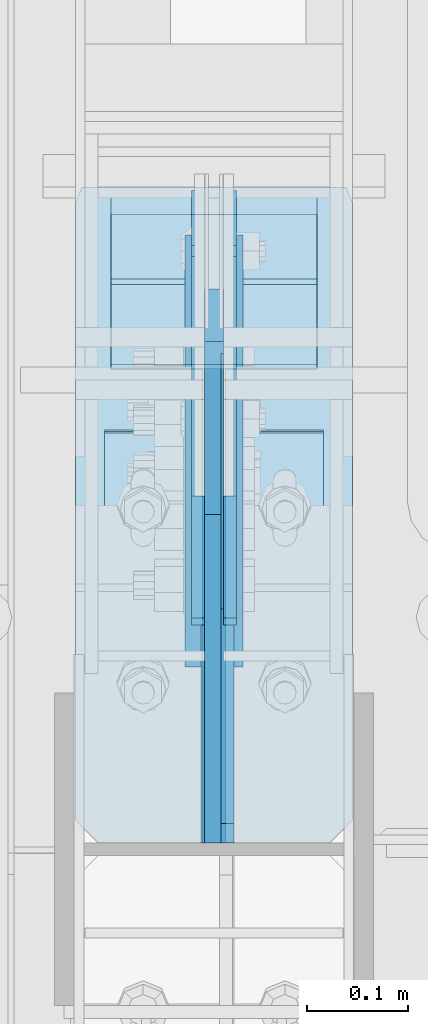
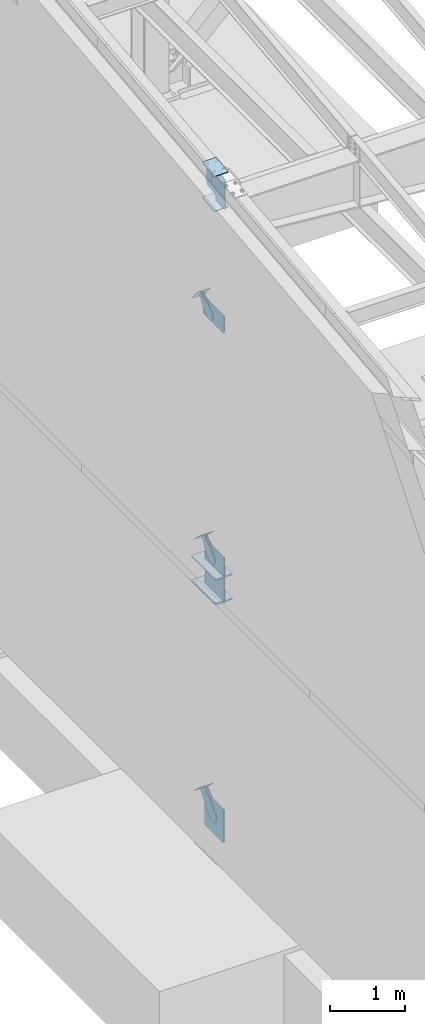
# One storey, part 991 of 1179: 17 plates, 10 elements without a shape of their own.
"""IFC2X3 building model written with IfcOpenShell, lengths in millimetres."""

from ifc_helpers import new_model, si_unit, frame, origin_with_axes, place, context, subcontext, project, spatial, faceted_brep, material, type_object, element, aggregate, save


model = new_model("IFC2X3")

# Units and contexts
model_context = context("Model", 3, precision=1e-05, world=origin_with_axes())
body_context = subcontext(model_context, "Body", "Model", "MODEL_VIEW")
ifc_project = project(units=[si_unit("LENGTHUNIT", "METRE", prefix="MILLI"), si_unit("AREAUNIT", "SQUARE_METRE"), si_unit("VOLUMEUNIT", "CUBIC_METRE"), si_unit("MASSUNIT", "GRAM", prefix="KILO"), si_unit("TIMEUNIT", "SECOND"), si_unit("PLANEANGLEUNIT", "RADIAN"), si_unit("SOLIDANGLEUNIT", "STERADIAN"), si_unit("THERMODYNAMICTEMPERATUREUNIT", "DEGREE_CELSIUS"), si_unit("LUMINOUSINTENSITYUNIT", "LUMEN")], contexts=[model_context])

# Site, building, storey
site_placement = place(None, origin_with_axes())
site = spatial("IfcSite", under=ifc_project, at=site_placement, CompositionType="ELEMENT")
building_placement = place(site_placement, origin_with_axes())
building = spatial("IfcBuilding", under=site, at=building_placement, Name="Undefined", CompositionType="ELEMENT")
storey_placement = place(building_placement, origin_with_axes())
storey = spatial("IfcBuildingStorey", under=building, at=storey_placement, Name="Undefined", CompositionType="ELEMENT", Elevation=0.0)

# Assembly, plates
assembly_1_placement = place(storey_placement, origin_with_axes())
assembly_1 = element("IfcElementAssembly", 1, at=assembly_1_placement, inside=storey, Name="COLUMN", AssemblyPlace="NOTDEFINED", PredefinedType="RIGID_FRAME")
ifc_material_1 = material(Name="STEEL/A572-GR.50")
plate_type_1 = type_object("IfcPlateType", PredefinedType="NOTDEFINED")
plate_1_placement = place(assembly_1_placement, frame((295.275012207031, 12133.5984303375, 3694.1125), z_axis=(0.0, -1.0, 0.0), x_axis=(1.0, 0.0, 0.0)))
plate_1 = element("IfcPlate", 2, at=plate_1_placement, type_object=plate_type_1, material=ifc_material_1, Name="PLATE", context=body_context, shape_type="Brep", body=[
    faceted_brep([(125.412487792968, -11.1125000000002, 646.448430322878), (125.412487792968, -11.1125000000002, 153.987500190735), (125.412487792968, 11.1125000000002, 153.987500190735), (125.412487792968, 11.1125000000002, 646.448430322878), (126.258376502454, -11.1125000000002, 149.734930475586), (126.258376502454, 11.1125000000002, 149.734930475586), (128.667263742896, -11.1125000000002, 146.12977594993), (128.667263742896, 11.1125000000002, 146.12977594993), (132.272418268556, -11.1125000000002, 143.720888709488), (132.272418268556, 11.1125000000002, 143.720888709488), (136.524987602239, -11.1125000000002, 142.875), (136.524987602239, 11.1125000000002, 142.875), (140.777557317386, -11.1125000000002, 143.720888709488), (140.777557317386, 11.1125000000002, 143.720888709488), (144.382711843045, -11.1125000000002, 146.12977594993), (144.382711843045, 11.1125000000002, 146.12977594993), (146.791599083488, -11.1125000000002, 149.734930475586), (146.791599083488, 11.1125000000002, 149.734930475586), (147.637487792974, -11.1125000000002, 153.987500190735), (147.637487792974, 11.1125000000002, 153.987500190735), (147.637487792974, -11.1125000000002, 646.448430322878), (147.637487792974, 11.1125000000002, 646.448430322878), (0.0, -11.1125000000002, 624.223429941409), (22.2250003814697, -11.1125000000002, 646.448430322878), (22.2250003814697, 11.1125000000002, 646.448430322878), (0.0, 11.1125000000002, 624.223429941409), (0.0, -11.1125000000002, 15.875), (0.0, 11.1125000000002, 15.875), (6.34999990463257, -11.1125000000002, 0.0), (6.34999990463257, 11.1125000000002, 0.0), (266.699987888336, -11.1125000000002, 0.0), (266.699987888336, 11.1125000000002, 0.0), (273.049987792969, -11.1125000000002, 15.875), (273.049987792969, 11.1125000000002, 15.875), (273.049987792969, -11.1125000000002, 624.223429941409), (273.049987792969, 11.1125000000002, 624.223429941409), (250.824987411499, -11.1125000000002, 646.448430322878), (250.824987411499, 11.1125000000002, 646.448430322878)], [[[0, 1, 2, 3]], [[4, 5, 2, 1]], [[6, 7, 5, 4]], [[8, 9, 7, 6]], [[10, 11, 9, 8]], [[12, 13, 11, 10]], [[14, 15, 13, 12]], [[16, 17, 15, 14]], [[18, 19, 17, 16]], [[20, 21, 19, 18]], [[22, 23, 24, 25]], [[26, 22, 25, 27]], [[28, 26, 27, 29]], [[30, 28, 29, 31]], [[32, 30, 31, 33]], [[34, 32, 33, 35]], [[36, 34, 35, 37]], [[16, 14, 12, 10, 8, 6, 4, 1, 0, 23, 22, 26, 28, 30, 32, 34, 36, 20, 18]], [[24, 23, 0, 3]], [[37, 35, 33, 31, 29, 27, 25, 24, 3, 2, 5, 7, 9, 11, 13, 15, 17, 19, 21]], [[36, 37, 21, 20]]]),
])
plate_2_placement = place(assembly_1_placement, frame((295.275012207031, 12133.5984303375, 4090.9875), z_axis=(0.0, -1.0, 0.0), x_axis=(1.0, 0.0, 0.0)))
plate_2 = element("IfcPlate", 3, at=plate_2_placement, type_object=plate_type_1, material=ifc_material_1, Name="PLATE", context=body_context, shape_type="Brep", body=[
    faceted_brep([(125.412487792968, -11.1125000000002, 646.448430322878), (125.412487792968, -11.1125000000002, 153.987500190735), (125.412487792968, 11.1125000000002, 153.987500190735), (125.412487792968, 11.1125000000002, 646.448430322878), (126.258376502454, -11.1125000000002, 149.734930475586), (126.258376502454, 11.1125000000002, 149.734930475586), (128.667263742896, -11.1125000000002, 146.12977594993), (128.667263742896, 11.1125000000002, 146.12977594993), (132.272418268556, -11.1125000000002, 143.720888709488), (132.272418268556, 11.1125000000002, 143.720888709488), (136.524987602239, -11.1125000000002, 142.875), (136.524987602239, 11.1125000000002, 142.875), (140.777557317386, -11.1125000000002, 143.720888709488), (140.777557317386, 11.1125000000002, 143.720888709488), (144.382711843045, -11.1125000000002, 146.12977594993), (144.382711843045, 11.1125000000002, 146.12977594993), (146.791599083488, -11.1125000000002, 149.734930475586), (146.791599083488, 11.1125000000002, 149.734930475586), (147.637487792974, -11.1125000000002, 153.987500190735), (147.637487792974, 11.1125000000002, 153.987500190735), (147.637487792974, -11.1125000000002, 646.448430322878), (147.637487792974, 11.1125000000002, 646.448430322878), (0.0, -11.1125000000002, 624.223429941409), (22.2250003814697, -11.1125000000002, 646.448430322878), (22.2250003814697, 11.1125000000002, 646.448430322878), (0.0, 11.1125000000002, 624.223429941409), (0.0, -11.1125000000002, 15.875), (0.0, 11.1125000000002, 15.875), (6.34999990463257, -11.1125000000002, 0.0), (6.34999990463257, 11.1125000000002, 0.0), (266.699987888336, -11.1125000000002, 0.0), (266.699987888336, 11.1125000000002, 0.0), (273.049987792969, -11.1125000000002, 15.875), (273.049987792969, 11.1125000000002, 15.875), (273.049987792969, -11.1125000000002, 624.223429941409), (273.049987792969, 11.1125000000002, 624.223429941409), (250.824987411499, -11.1125000000002, 646.448430322878), (250.824987411499, 11.1125000000002, 646.448430322878)], [[[0, 1, 2, 3]], [[4, 5, 2, 1]], [[6, 7, 5, 4]], [[8, 9, 7, 6]], [[10, 11, 9, 8]], [[12, 13, 11, 10]], [[14, 15, 13, 12]], [[16, 17, 15, 14]], [[18, 19, 17, 16]], [[20, 21, 19, 18]], [[22, 23, 24, 25]], [[26, 22, 25, 27]], [[28, 26, 27, 29]], [[30, 28, 29, 31]], [[32, 30, 31, 33]], [[34, 32, 33, 35]], [[36, 34, 35, 37]], [[16, 14, 12, 10, 8, 6, 4, 1, 0, 23, 22, 26, 28, 30, 32, 34, 36, 20, 18]], [[24, 23, 0, 3]], [[37, 35, 33, 31, 29, 27, 25, 24, 3, 2, 5, 7, 9, 11, 13, 15, 17, 19, 21]], [[36, 37, 21, 20]]]),
])

# Assembly, plate
assembly_2_placement = place(storey_placement, origin_with_axes())
assembly_2 = element("IfcElementAssembly", 4, at=assembly_2_placement, inside=storey, AssemblyPlace="NOTDEFINED", PredefinedType="RIGID_FRAME")
ifc_material_2 = material(Name="STEEL/A36")
plate_type_2 = type_object("IfcPlateType", PredefinedType="NOTDEFINED")
plate_3_placement = place(assembly_2_placement, frame((415.925000000002, 12073.4870321748, 8239.67476675301), z_axis=(0.0, -0.591856615182528, 0.806043266248581), x_axis=(0.0, 0.806043266248581, 0.591856615182528)))
plate_3 = element("IfcPlate", 5, at=plate_3_placement, type_object=plate_type_2, material=ifc_material_2, context=body_context, shape_type="Brep", body=[
    faceted_brep([(0.0, -6.34999999999854, 0.0), (-101.600000000211, -6.34999999999854, -44.6881937825565), (-101.600000000211, 6.34999999999854, -44.6881937825565), (0.0, 6.34999999999854, 0.0), (-246.684985848258, -6.34999999999854, -44.6881937827675), (-246.684985848258, 6.34999999999854, -44.6881937827675), (-281.313054102191, -6.34999999999854, -37.800242748639), (-281.313054102191, 6.34999999999854, -37.800242748639), (-310.669312868691, -6.34999999999854, -18.1850177516608), (-310.669312868691, 6.34999999999854, -18.1850177516608), (-330.284537865713, -6.34999999999854, 11.1712410148393), (-330.284537865713, 6.34999999999854, 11.1712410148393), (-337.172488899912, -6.34999999999854, 45.7993031647638), (-337.172488899912, 6.34999999999854, 45.7993031647638), (-330.284537865768, -6.34999999999854, 80.4273714187839), (-330.284537865768, 6.34999999999854, 80.4273714187839), (-310.669312868773, -6.34999999999854, 109.783630185371), (-310.669312868773, 6.34999999999854, 109.783630185371), (-281.313054102271, -6.34999999999854, 129.398855182466), (-281.313054102271, 6.34999999999854, 129.398855182466), (-246.684988899762, -6.34999999999854, 136.286806216707), (-246.684988899762, 6.34999999999854, 136.286806216707), (-101.600000000377, -6.34999999999854, 136.286806216911), (-101.600000000377, 6.34999999999854, 136.286806216911), (-8.18545231595635e-11, -6.34999999999854, 91.5986124346418), (-8.18545231595635e-11, 6.34999999999854, 91.5986124346418), (69.8500000000859, -6.35000000000002, 91.598612434588), (69.8500000000859, 6.35000000000002, 91.598612434588), (69.849999425729, -6.34999999999854, 0.0), (69.849999425729, 6.34999999999854, 0.0)], [[[0, 1, 2, 3]], [[1, 4, 5, 2]], [[4, 6, 7, 5]], [[6, 8, 9, 7]], [[8, 10, 11, 9]], [[10, 12, 13, 11]], [[12, 14, 15, 13]], [[14, 16, 17, 15]], [[16, 18, 19, 17]], [[18, 20, 21, 19]], [[20, 22, 23, 21]], [[22, 24, 25, 23]], [[24, 26, 27, 25]], [[26, 28, 29, 27]], [[28, 0, 3, 29]], [[5, 7, 9, 11, 13, 15, 17, 19, 21, 23, 25, 27, 29, 3, 2]], [[28, 26, 24, 22, 20, 18, 16, 14, 12, 10, 8, 6, 4, 1, 0]]]),
])
aggregate(assembly_2, [plate_3])

assembly_3_placement = place(storey_placement, origin_with_axes())
assembly_3 = element("IfcElementAssembly", 6, at=assembly_3_placement, inside=storey, AssemblyPlace="NOTDEFINED", PredefinedType="RIGID_FRAME")
plate_4_placement = place(assembly_3_placement, frame((447.675000000002, 12073.4870321748, 8239.67476675301), z_axis=(0.0, -0.591856615182528, 0.806043266248581), x_axis=(0.0, 0.806043266248581, 0.591856615182528)))
plate_4 = element("IfcPlate", 7, at=plate_4_placement, type_object=plate_type_2, material=ifc_material_2, context=body_context, shape_type="Brep", body=[
    faceted_brep([(0.0, -6.34999999999854, 0.0), (-101.600000000211, -6.34999999999854, -44.6881937825565), (-101.600000000211, 6.34999999999854, -44.6881937825565), (0.0, 6.34999999999854, 0.0), (-246.684985848258, -6.34999999999854, -44.6881937827675), (-246.684985848258, 6.34999999999854, -44.6881937827675), (-281.313054102191, -6.34999999999854, -37.800242748639), (-281.313054102191, 6.34999999999854, -37.800242748639), (-310.669312868691, -6.34999999999854, -18.1850177516608), (-310.669312868691, 6.34999999999854, -18.1850177516608), (-330.284537865713, -6.34999999999854, 11.1712410148393), (-330.284537865713, 6.34999999999854, 11.1712410148393), (-337.172488899912, -6.34999999999854, 45.7993031647638), (-337.172488899912, 6.34999999999854, 45.7993031647638), (-330.284537865768, -6.34999999999854, 80.4273714187839), (-330.284537865768, 6.34999999999854, 80.4273714187839), (-310.669312868773, -6.34999999999854, 109.783630185371), (-310.669312868773, 6.34999999999854, 109.783630185371), (-281.313054102271, -6.34999999999854, 129.398855182466), (-281.313054102271, 6.34999999999854, 129.398855182466), (-246.684988899762, -6.34999999999854, 136.286806216707), (-246.684988899762, 6.34999999999854, 136.286806216707), (-101.600000000377, -6.34999999999854, 136.286806216911), (-101.600000000377, 6.34999999999854, 136.286806216911), (-8.18545231595635e-11, -6.34999999999854, 91.5986124346418), (-8.18545231595635e-11, 6.34999999999854, 91.5986124346418), (69.8500000000859, -6.35000000000002, 91.598612434588), (69.8500000000859, 6.35000000000002, 91.598612434588), (69.849999425729, -6.34999999999854, 0.0), (69.849999425729, 6.34999999999854, 0.0)], [[[0, 1, 2, 3]], [[1, 4, 5, 2]], [[4, 6, 7, 5]], [[6, 8, 9, 7]], [[8, 10, 11, 9]], [[10, 12, 13, 11]], [[12, 14, 15, 13]], [[14, 16, 17, 15]], [[16, 18, 19, 17]], [[18, 20, 21, 19]], [[20, 22, 23, 21]], [[22, 24, 25, 23]], [[24, 26, 27, 25]], [[26, 28, 29, 27]], [[28, 0, 3, 29]], [[5, 7, 9, 11, 13, 15, 17, 19, 21, 23, 25, 27, 29, 3, 2]], [[28, 26, 24, 22, 20, 18, 16, 14, 12, 10, 8, 6, 4, 1, 0]]]),
])
aggregate(assembly_3, [plate_4])

assembly_4_placement = place(storey_placement, origin_with_axes())
assembly_4 = element("IfcElementAssembly", 8, at=assembly_4_placement, inside=storey, Name="Plate", AssemblyPlace="NOTDEFINED", PredefinedType="RIGID_FRAME")
plate_type_3 = type_object("IfcPlateType", PredefinedType="NOTDEFINED")
plate_5_placement = place(assembly_4_placement, frame((533.400000000002, 12160.2559766978, 8234.1590330937), z_axis=(0.0, -0.591856615182528, 0.806043266248581), x_axis=(-1.0, 0.0, 0.0)))
plate_5 = element("IfcPlate", 9, at=plate_5_placement, type_object=plate_type_3, material=ifc_material_2, Name="Plate", context=body_context, shape_type="Brep", body=[
    faceted_brep([(0.0, -3.17500000000109, 0.0), (0.0, -3.17500000000291, 203.200000000368), (0.0, 3.17499999998836, 203.200000000361), (0.0, 3.17500000000109, 7.27595761418343e-12), (203.199999999997, -3.17500000000291, 203.200000000368), (203.199999999997, 3.17499999998836, 203.200000000361), (203.199999999997, -3.17499999999927, 3.63797880709171e-12), (203.199999999997, 3.17499999999382, -3.63797880709171e-12)], [[[0, 1, 2, 3]], [[1, 4, 5, 2]], [[4, 6, 7, 5]], [[6, 0, 3, 7]], [[5, 7, 3, 2]], [[6, 4, 1, 0]]]),
])
aggregate(assembly_4, [plate_5])

assembly_5_placement = place(storey_placement, origin_with_axes())
assembly_5 = element("IfcElementAssembly", 10, at=assembly_5_placement, inside=storey, Name="Plate", AssemblyPlace="NOTDEFINED", PredefinedType="RIGID_FRAME")
plate_6_placement = place(assembly_5_placement, frame((533.400000000002, 12095.1065773874, 4376.5010438093), z_axis=(0.0, -0.715642339037758, 0.698466923036852), x_axis=(-1.0, 0.0, 0.0)))
plate_6 = element("IfcPlate", 11, at=plate_6_placement, type_object=plate_type_3, material=ifc_material_2, Name="Plate", context=body_context, shape_type="Brep", body=[
    faceted_brep([(0.0, -3.17500000000109, 0.0), (0.0, -3.17500000000291, 203.200000000368), (0.0, 3.17499999998836, 203.200000000361), (0.0, 3.17500000000109, 7.27595761418343e-12), (203.199999999997, -3.17500000000291, 203.200000000368), (203.199999999997, 3.17499999998836, 203.200000000361), (203.199999999997, -3.17499999999927, 3.63797880709171e-12), (203.199999999997, 3.17499999999382, -3.63797880709171e-12)], [[[0, 1, 2, 3]], [[1, 4, 5, 2]], [[4, 6, 7, 5]], [[6, 0, 3, 7]], [[5, 7, 3, 2]], [[6, 4, 1, 0]]]),
])
aggregate(assembly_5, [plate_6])

assembly_6_placement = place(storey_placement, origin_with_axes())
assembly_6 = element("IfcElementAssembly", 12, at=assembly_6_placement, inside=storey, Name="Plate", AssemblyPlace="NOTDEFINED", PredefinedType="RIGID_FRAME")
plate_7_placement = place(assembly_6_placement, frame((533.400000000002, 12104.3203289467, 297.334564216516), z_axis=(0.0, -0.727605443744034, 0.685995858758671), x_axis=(-1.0, 0.0, 0.0)))
plate_7 = element("IfcPlate", 13, at=plate_7_placement, type_object=plate_type_3, material=ifc_material_2, Name="Plate", context=body_context, shape_type="Brep", body=[
    faceted_brep([(0.0, -3.17500000000109, 0.0), (0.0, -3.17500000000291, 203.200000000368), (0.0, 3.17499999998836, 203.200000000361), (0.0, 3.17500000000109, 7.27595761418343e-12), (203.199999999997, -3.17500000000291, 203.200000000368), (203.199999999997, 3.17499999998836, 203.200000000361), (203.199999999997, -3.17499999999927, 3.63797880709171e-12), (203.199999999997, 3.17499999999382, -3.63797880709171e-12)], [[[0, 1, 2, 3]], [[1, 4, 5, 2]], [[4, 6, 7, 5]], [[6, 0, 3, 7]], [[5, 7, 3, 2]], [[6, 4, 1, 0]]]),
])
aggregate(assembly_6, [plate_7])

# Plate
plate_type_4 = type_object("IfcPlateType", PredefinedType="NOTDEFINED")
plate_8_placement = place(assembly_1_placement, frame((323.850003077961, 11891.8732407573, 10597.0457775071), z_axis=(1.0, 0.0, 0.0), x_axis=(0.0, -0.993676146336441, -0.112284087038017)))
plate_8 = element("IfcPlate", 14, at=plate_8_placement, type_object=plate_type_4, material=ifc_material_1, Name="PLATE", context=body_context, shape_type="Brep", body=[
    faceted_brep([(0.0, -6.34999999999854, 0.0), (0.0, -6.350000000004, 215.899993896484), (0.0, 6.35000000000582, 215.899993896484), (0.0, 6.34999999999854, 0.0), (330.200000001782, -6.34999999994034, 215.899993896483), (330.200000001782, 6.35000000006767, 215.899993896483), (330.200000001782, -6.34999999994034, -1.47792889038101e-12), (330.200000001782, 6.35000000006767, -1.47792889038101e-12)], [[[0, 1, 2, 3]], [[1, 4, 5, 2]], [[4, 6, 7, 5]], [[6, 0, 3, 7]], [[5, 7, 3, 2]], [[6, 4, 1, 0]]]),
])

plate_9_placement = place(assembly_1_placement, frame((323.850003061394, 11893.2992487638, 10031.646117351), z_axis=(1.0, 0.0, 0.0), x_axis=(0.0, -0.993676146336441, -0.112284087038017)))
plate_9 = element("IfcPlate", 15, at=plate_9_placement, type_object=plate_type_4, material=ifc_material_1, Name="PLATE", context=body_context, shape_type="Brep", body=[
    faceted_brep([(0.0, -6.34999999999854, 0.0), (0.0, -6.350000000004, 215.899993896484), (0.0, 6.35000000000582, 215.899993896484), (0.0, 6.34999999999854, 0.0), (330.200000001782, -6.34999999994034, 215.899993896483), (330.200000001782, 6.35000000006767, 215.899993896483), (330.200000001782, -6.34999999994034, -1.47792889038101e-12), (330.200000001782, 6.35000000006767, -1.47792889038101e-12)], [[[0, 1, 2, 3]], [[1, 4, 5, 2]], [[4, 6, 7, 5]], [[6, 0, 3, 7]], [[5, 7, 3, 2]], [[6, 4, 1, 0]]]),
])

plate_type_5 = type_object("IfcPlateType", PredefinedType="NOTDEFINED")
plate_10_placement = place(assembly_1_placement, frame((445.293750000002, 11487.15, 10039.8278383638), z_axis=(0.0, 0.663574933899741, 0.748109822886957), x_axis=(0.0, 0.748109822886957, -0.663574933899741)))
plate_10 = element("IfcPlate", 16, at=plate_10_placement, type_object=plate_type_5, material=ifc_material_1, Name="PLATE", context=body_context, shape_type="Brep", body=[
    faceted_brep([(-303.225076522439, -6.35000000000002, 370.402055885486), (-303.355824945647, 6.35000000000002, 370.519714327758), (-303.434077016447, 6.35000000000002, 342.089767131616), (-303.434077016447, -6.35000000000002, 342.089767131616), (25.4641550948563, -6.35000000000002, 0.0), (0.0, -6.34999999999854, 0.0), (0.0, 6.34999999999854, 0.0), (25.4641550948563, 6.35000000000002, 0.0), (167.045917247172, -6.35000000000002, 157.353263970723), (167.045917247172, 6.35000000000002, 157.353263970723), (131.563526715495, -6.35000000000002, 197.355899250204), (131.563526715495, 6.35000000000002, 197.355899250204), (126.802866418006, -6.35000000000002, 205.238730036501), (126.802866418006, 6.35000000000002, 205.238730036501), (125.165683086001, -6.35000000000002, 214.300878700633), (125.165683086001, 6.35000000000002, 214.300878700633), (126.867175912115, -6.35000000000002, 223.351173161929), (126.867175912115, 6.35000000000002, 223.351173161929), (131.683692556814, -6.35000000000002, 231.199999512715), (131.683692556814, 6.35000000000002, 231.199999512715), (286.794657668127, -6.35000000000002, 403.589566389341), (286.794657668127, 6.35000000000002, 403.589566389341), (23.8827060644498, -6.35000000000002, 699.99493122035), (23.8827060644498, 6.35000000000002, 699.99493122035), (-127.388721232707, -6.35000000000002, 531.872607863961), (-127.388721232707, 6.35000000000002, 531.872607863961), (-134.060951024564, -6.35000000000002, 526.588932486246), (-134.060951024564, 6.35000000000002, 526.588932486246), (-142.104023886786, -6.35000000000002, 523.805974558898), (-142.104023886786, 6.35000000000002, 523.805974558898), (-150.614897093323, -6.35000000000002, 523.836193008534), (-150.614897093323, 6.35000000000002, 523.836193008534), (-158.638005243585, -6.35000000000002, 526.676195033468), (-158.638005243585, 6.35000000000002, 526.676195033468), (-161.072657901749, 6.35000000000002, 528.632463238393), (-161.072657901749, -6.35000000000002, 528.632463238393)], [[[0, 1, 2, 3]], [[4, 5, 6, 7]], [[8, 4, 7, 9]], [[10, 8, 9, 11]], [[12, 10, 11, 13]], [[14, 12, 13, 15]], [[16, 14, 15, 17]], [[18, 16, 17, 19]], [[20, 18, 19, 21]], [[22, 20, 21, 23]], [[24, 22, 23, 25]], [[26, 24, 25, 27]], [[28, 26, 27, 29]], [[30, 28, 29, 31]], [[32, 30, 31, 33]], [[32, 33, 34, 35]], [[5, 4, 8, 10, 12, 14, 16, 18, 20, 22, 24, 26, 28, 30, 32, 35, 0, 3]], [[6, 5, 3, 2]], [[34, 33, 31, 29, 27, 25, 23, 21, 19, 17, 15, 13, 11, 9, 7, 6, 2, 1]], [[35, 34, 1, 0]]]),
])

# Assembly, plate
assembly_7_placement = place(storey_placement, origin_with_axes())
assembly_7 = element("IfcElementAssembly", 17, at=assembly_7_placement, inside=storey, AssemblyPlace="NOTDEFINED", PredefinedType="RIGID_FRAME")
plate_type_6 = type_object("IfcPlateType", PredefinedType="NOTDEFINED")
plate_11_placement = place(assembly_7_placement, frame((415.925000000002, 12007.0986468691, 4351.4824408121), z_axis=(0.0, -0.715642339037758, 0.698466923036852), x_axis=(0.0, 0.698466923036852, 0.715642339037758)))
plate_11 = element("IfcPlate", 18, at=plate_11_placement, type_object=plate_type_6, material=ifc_material_2, context=body_context, shape_type="Brep", body=[
    faceted_brep([(0.0, -6.34999999999854, 0.0), (-101.599999999963, -6.34999999999854, -37.5700345970108), (-101.599999999963, 6.34999999999854, -37.5700345970108), (0.0, 6.34999999999854, 0.0), (-245.369242323884, -6.34999999999854, -37.5700345970945), (-245.369242323884, 6.34999999999854, -37.5700345970945), (-281.212328723803, -6.34999999999854, -30.4404014271258), (-281.212328723803, 6.34999999999854, -30.4404014271258), (-311.598630137756, -6.34999999999854, -10.1369239370142), (-311.598630137756, 6.34999999999854, -10.1369239370142), (-331.902107627997, -6.34999999999854, 20.24937747687), (-331.902107627997, 6.34999999999854, 20.24937747687), (-339.031740798124, -6.34999999999854, 56.0924669287269), (-339.031740798124, 6.34999999999854, 56.0924669287269), (-331.902107628228, -6.34999999999854, 91.9355533287926), (-331.902107628228, 6.34999999999854, 91.9355533287926), (-311.598630138099, -6.34999999999854, 122.321854742866), (-311.598630138099, 6.34999999999854, 122.321854742866), (-281.212328724136, -6.34999999999854, 142.625332233139), (-281.212328724136, 6.34999999999854, 142.625332233139), (-245.36924079839, -6.34999999999854, 149.754965403199), (-245.36924079839, 6.34999999999854, 149.754965403199), (-101.600000000685, -6.34999999999854, 149.75496540329), (-101.600000000685, 6.34999999999854, 149.75496540329), (-4.35647962149233e-10, -6.34999999999854, 112.184930806416), (-4.35647962149233e-10, 6.34999999999854, 112.184930806416), (82.5499999996491, -6.34999999999854, 112.184930806461), (82.5499999996491, 6.34999999999854, 112.184930806461), (82.550000000203, -6.34999999999854, 1.2732925824821e-10), (82.550000000203, 6.34999999999854, 1.2732925824821e-10)], [[[0, 1, 2, 3]], [[1, 4, 5, 2]], [[4, 6, 7, 5]], [[6, 8, 9, 7]], [[8, 10, 11, 9]], [[10, 12, 13, 11]], [[12, 14, 15, 13]], [[14, 16, 17, 15]], [[16, 18, 19, 17]], [[18, 20, 21, 19]], [[20, 22, 23, 21]], [[22, 24, 25, 23]], [[24, 26, 27, 25]], [[26, 28, 29, 27]], [[28, 0, 3, 29]], [[5, 7, 9, 11, 13, 15, 17, 19, 21, 23, 25, 27, 29, 3, 2]], [[28, 26, 24, 22, 20, 18, 16, 14, 12, 10, 8, 6, 4, 1, 0]]]),
])
aggregate(assembly_7, [plate_11])

assembly_8_placement = place(storey_placement, origin_with_axes())
assembly_8 = element("IfcElementAssembly", 19, at=assembly_8_placement, inside=storey, AssemblyPlace="NOTDEFINED", PredefinedType="RIGID_FRAME")
plate_12_placement = place(assembly_8_placement, frame((447.675000000002, 12007.0986468691, 4351.4824408121), z_axis=(0.0, -0.715642339037758, 0.698466923036852), x_axis=(0.0, 0.698466923036852, 0.715642339037758)))
plate_12 = element("IfcPlate", 20, at=plate_12_placement, type_object=plate_type_6, material=ifc_material_2, context=body_context, shape_type="Brep", body=[
    faceted_brep([(0.0, -6.34999999999854, 0.0), (-101.599999999963, -6.34999999999854, -37.5700345970108), (-101.599999999963, 6.34999999999854, -37.5700345970108), (0.0, 6.34999999999854, 0.0), (-245.369242323884, -6.34999999999854, -37.5700345970945), (-245.369242323884, 6.34999999999854, -37.5700345970945), (-281.212328723803, -6.34999999999854, -30.4404014271258), (-281.212328723803, 6.34999999999854, -30.4404014271258), (-311.598630137756, -6.34999999999854, -10.1369239370142), (-311.598630137756, 6.34999999999854, -10.1369239370142), (-331.902107627997, -6.34999999999854, 20.24937747687), (-331.902107627997, 6.34999999999854, 20.24937747687), (-339.031740798124, -6.34999999999854, 56.0924669287269), (-339.031740798124, 6.34999999999854, 56.0924669287269), (-331.902107628228, -6.34999999999854, 91.9355533287926), (-331.902107628228, 6.34999999999854, 91.9355533287926), (-311.598630138099, -6.34999999999854, 122.321854742866), (-311.598630138099, 6.34999999999854, 122.321854742866), (-281.212328724136, -6.34999999999854, 142.625332233139), (-281.212328724136, 6.34999999999854, 142.625332233139), (-245.36924079839, -6.34999999999854, 149.754965403199), (-245.36924079839, 6.34999999999854, 149.754965403199), (-101.600000000685, -6.34999999999854, 149.75496540329), (-101.600000000685, 6.34999999999854, 149.75496540329), (-4.35647962149233e-10, -6.34999999999854, 112.184930806416), (-4.35647962149233e-10, 6.34999999999854, 112.184930806416), (82.5499999996491, -6.34999999999854, 112.184930806461), (82.5499999996491, 6.34999999999854, 112.184930806461), (82.550000000203, -6.34999999999854, 1.2732925824821e-10), (82.550000000203, 6.34999999999854, 1.2732925824821e-10)], [[[0, 1, 2, 3]], [[1, 4, 5, 2]], [[4, 6, 7, 5]], [[6, 8, 9, 7]], [[8, 10, 11, 9]], [[10, 12, 13, 11]], [[12, 14, 15, 13]], [[14, 16, 17, 15]], [[16, 18, 19, 17]], [[18, 20, 21, 19]], [[20, 22, 23, 21]], [[22, 24, 25, 23]], [[24, 26, 27, 25]], [[26, 28, 29, 27]], [[28, 0, 3, 29]], [[5, 7, 9, 11, 13, 15, 17, 19, 21, 23, 25, 27, 29, 3, 2]], [[28, 26, 24, 22, 20, 18, 16, 14, 12, 10, 8, 6, 4, 1, 0]]]),
])
aggregate(assembly_8, [plate_12])

# Plate
plate_type_7 = type_object("IfcPlateType", PredefinedType="NOTDEFINED")
plate_13_placement = place(assembly_1_placement, frame((431.800000000002, 11487.15, 8026.4), z_axis=(0.0, 0.0, 1.0), x_axis=(0.0, 1.0, 0.0)))
plate_13 = element("IfcPlate", 21, at=plate_13_placement, type_object=plate_type_7, material=ifc_material_1, Name="PLATE", context=body_context, shape_type="Brep", body=[
    faceted_brep([(0.0, -9.52500000000146, 19.0499992370605), (0.0, -9.52499999999998, 283.468697373038), (0.0, 9.52499999999998, 283.468697373038), (0.0, 9.52500000000146, 19.0499992370605), (408.747629502155, -9.52499999999998, 283.468697373038), (408.747629502155, 9.52499999999998, 283.468697373038), (545.925196486085, -9.52499999999998, 96.6480193382731), (545.925196486085, 9.52499999999998, 96.6480193382731), (545.925196486085, -9.52499999999998, 0.0), (545.925196486085, 9.52499999999998, 0.0), (19.0499992370605, -9.52500000000146, 0.0), (19.0499992370605, 9.52500000000146, 0.0)], [[[0, 1, 2, 3]], [[1, 4, 5, 2]], [[4, 6, 7, 5]], [[6, 8, 9, 7]], [[8, 10, 11, 9]], [[10, 0, 3, 11]], [[5, 7, 9, 11, 3, 2]], [[10, 8, 6, 4, 1, 0]]]),
])

plate_type_8 = type_object("IfcPlateType", PredefinedType="NOTDEFINED")
plate_14_placement = place(assembly_1_placement, frame((431.800000000002, 11487.15, 3663.95), z_axis=(0.0, 0.0, 1.0), x_axis=(0.0, 1.0, 0.0)))
plate_14 = element("IfcPlate", 22, at=plate_14_placement, type_object=plate_type_8, material=ifc_material_1, Name="PLATE", context=body_context, shape_type="Brep", body=[
    faceted_brep([(0.0, -9.52499999999964, 0.0), (-3.63797880709171e-12, -9.52499999999998, 737.163128918689), (-3.63797880709171e-12, 9.52499999999998, 737.163128918689), (0.0, 9.52499999999964, 0.0), (323.636098339506, -9.52499999999998, 737.163128918689), (323.636098339506, 9.52499999999998, 737.163128918689), (494.048430322873, -9.52499999999998, 570.84069287054), (494.048430322873, 9.52499999999998, 570.84069287054), (494.048430322877, -9.52499999999998, 0.0), (494.048430322877, 9.52499999999998, 0.0)], [[[0, 1, 2, 3]], [[1, 4, 5, 2]], [[4, 6, 7, 5]], [[6, 8, 9, 7]], [[8, 0, 3, 9]], [[5, 7, 9, 3, 2]], [[8, 6, 4, 1, 0]]]),
])

plate_type_9 = type_object("IfcPlateType", PredefinedType="NOTDEFINED")
plate_15_placement = place(assembly_1_placement, frame((431.800000000002, 11487.15, -215.9), z_axis=(0.0, 0.0, 1.0), x_axis=(0.0, 1.0, 0.0)))
plate_15 = element("IfcPlate", 23, at=plate_15_placement, type_object=plate_type_9, material=ifc_material_1, Name="PLATE", context=body_context, shape_type="Brep", body=[
    faceted_brep([(0.0, -12.7000000000007, 19.0500000000029), (0.0, -12.7, 534.018748335632), (0.0, 12.7, 534.018748335632), (0.0, 12.7000000000007, 19.0500000000029), (331.311918860847, -12.7, 534.018748335632), (331.311918860847, 12.7, 534.018748335632), (506.88311243628, -12.7, 368.487947617164), (506.88311243628, 12.7, 368.487947617164), (506.88311243628, -12.7, 0.0), (506.88311243628, 12.7, 0.0), (19.0499992370605, -12.6999999999971, 0.0), (19.0499992370605, 12.6999999999971, 0.0)], [[[0, 1, 2, 3]], [[1, 4, 5, 2]], [[4, 6, 7, 5]], [[6, 8, 9, 7]], [[8, 10, 11, 9]], [[10, 0, 3, 11]], [[5, 7, 9, 11, 3, 2]], [[10, 8, 6, 4, 1, 0]]]),
])

aggregate(assembly_1, [plate_1, plate_2, plate_8, plate_9, plate_10, plate_13, plate_14, plate_15])

# Assembly, plate
assembly_9_placement = place(storey_placement, origin_with_axes())
assembly_9 = element("IfcElementAssembly", 24, at=assembly_9_placement, inside=storey, AssemblyPlace="NOTDEFINED", PredefinedType="RIGID_FRAME")
plate_type_10 = type_object("IfcPlateType", PredefinedType="NOTDEFINED")
plate_16_placement = place(assembly_9_placement, frame((411.162500000002, 12029.3890753335, 258.890005327183), z_axis=(0.0, -0.727605443744034, 0.685995858758671), x_axis=(0.0, 0.685995858758672, 0.727605443744034)))
plate_16 = element("IfcPlate", 25, at=plate_16_placement, type_object=plate_type_10, material=ifc_material_2, context=body_context, shape_type="Brep", body=[
    faceted_brep([(0.0, -7.9375, 0.0), (-101.600000000497, -7.9375, -21.7975798445477), (-101.600000000497, 7.9375, -21.7975798445477), (0.0, 7.9375, 0.0), (-320.921138851689, -7.9375, -21.7975798443877), (-320.921138851689, 7.9375, -21.7975798443877), (-357.371735784433, -7.9375, -14.5471053160727), (-357.371735784433, 7.9375, -14.5471053160727), (-388.273059759649, -7.9375, 6.10049924760824), (-388.273059759649, 7.9375, 6.10049924760824), (-408.920664323319, -7.9375, 37.0018232228431), (-408.920664323319, 7.9375, 37.0018232228431), (-416.171138851623, -7.9375, 73.4524201546446), (-416.171138851623, 7.9375, 73.4524201546446), (-408.920664323337, -7.9375, 109.903017087447), (-408.920664323337, 7.9375, 109.903017087447), (-388.273059759656, -7.9375, 140.804341062707), (-388.273059759656, 7.9375, 140.804341062707), (-357.3717357844, -7.9375, 161.451945626395), (-357.3717357844, 7.9375, 161.451945626395), (-320.921138851201, -7.9375, 168.702420154674), (-320.921138851201, 7.9375, 168.702420154674), (-101.600000000592, -7.9375, 168.702420154521), (-101.600000000592, 7.9375, 168.702420154521), (-8.00355337560177e-11, -7.9375, 146.904840309817), (-8.00355337560177e-11, 7.9375, 146.904840309817), (82.5499999998137, -7.9375, 146.90484031055), (82.5499999998137, 7.9375, 146.90484031055), (82.5500000000975, -7.9375, -6.91215973347425e-11), (82.5500000000975, 7.9375, -6.91215973347425e-11)], [[[0, 1, 2, 3]], [[1, 4, 5, 2]], [[4, 6, 7, 5]], [[6, 8, 9, 7]], [[8, 10, 11, 9]], [[10, 12, 13, 11]], [[12, 14, 15, 13]], [[14, 16, 17, 15]], [[16, 18, 19, 17]], [[18, 20, 21, 19]], [[20, 22, 23, 21]], [[22, 24, 25, 23]], [[24, 26, 27, 25]], [[26, 28, 29, 27]], [[28, 0, 3, 29]], [[5, 7, 9, 11, 13, 15, 17, 19, 21, 23, 25, 27, 29, 3, 2]], [[28, 26, 24, 22, 20, 18, 16, 14, 12, 10, 8, 6, 4, 1, 0]]]),
])
aggregate(assembly_9, [plate_16])

assembly_10_placement = place(storey_placement, origin_with_axes())
assembly_10 = element("IfcElementAssembly", 26, at=assembly_10_placement, inside=storey, AssemblyPlace="NOTDEFINED", PredefinedType="RIGID_FRAME")
plate_17_placement = place(assembly_10_placement, frame((452.437500000002, 12029.3890753335, 258.890005327183), z_axis=(0.0, -0.727605443744034, 0.685995858758671), x_axis=(0.0, 0.685995858758672, 0.727605443744034)))
plate_17 = element("IfcPlate", 27, at=plate_17_placement, type_object=plate_type_10, material=ifc_material_2, context=body_context, shape_type="Brep", body=[
    faceted_brep([(0.0, -7.9375, 0.0), (-101.600000000497, -7.9375, -21.7975798445477), (-101.600000000497, 7.9375, -21.7975798445477), (0.0, 7.9375, 0.0), (-320.921138851689, -7.9375, -21.7975798443877), (-320.921138851689, 7.9375, -21.7975798443877), (-357.371735784433, -7.9375, -14.5471053160727), (-357.371735784433, 7.9375, -14.5471053160727), (-388.273059759649, -7.9375, 6.10049924760824), (-388.273059759649, 7.9375, 6.10049924760824), (-408.920664323319, -7.9375, 37.0018232228431), (-408.920664323319, 7.9375, 37.0018232228431), (-416.171138851623, -7.9375, 73.4524201546446), (-416.171138851623, 7.9375, 73.4524201546446), (-408.920664323337, -7.9375, 109.903017087447), (-408.920664323337, 7.9375, 109.903017087447), (-388.273059759656, -7.9375, 140.804341062707), (-388.273059759656, 7.9375, 140.804341062707), (-357.3717357844, -7.9375, 161.451945626395), (-357.3717357844, 7.9375, 161.451945626395), (-320.921138851201, -7.9375, 168.702420154674), (-320.921138851201, 7.9375, 168.702420154674), (-101.600000000592, -7.9375, 168.702420154521), (-101.600000000592, 7.9375, 168.702420154521), (-8.00355337560177e-11, -7.9375, 146.904840309817), (-8.00355337560177e-11, 7.9375, 146.904840309817), (82.5499999998137, -7.9375, 146.90484031055), (82.5499999998137, 7.9375, 146.90484031055), (82.5500000000975, -7.9375, -6.91215973347425e-11), (82.5500000000975, 7.9375, -6.91215973347425e-11)], [[[0, 1, 2, 3]], [[1, 4, 5, 2]], [[4, 6, 7, 5]], [[6, 8, 9, 7]], [[8, 10, 11, 9]], [[10, 12, 13, 11]], [[12, 14, 15, 13]], [[14, 16, 17, 15]], [[16, 18, 19, 17]], [[18, 20, 21, 19]], [[20, 22, 23, 21]], [[22, 24, 25, 23]], [[24, 26, 27, 25]], [[26, 28, 29, 27]], [[28, 0, 3, 29]], [[5, 7, 9, 11, 13, 15, 17, 19, 21, 23, 25, 27, 29, 3, 2]], [[28, 26, 24, 22, 20, 18, 16, 14, 12, 10, 8, 6, 4, 1, 0]]]),
])
aggregate(assembly_10, [plate_17])

save(model, "model.ifc")
